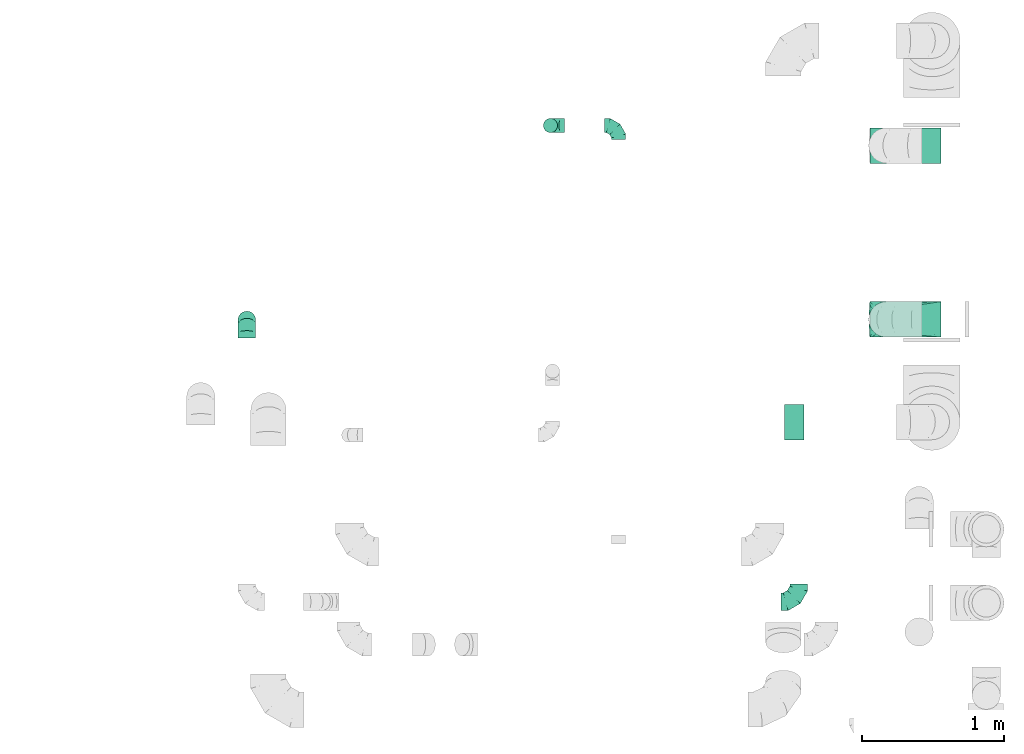
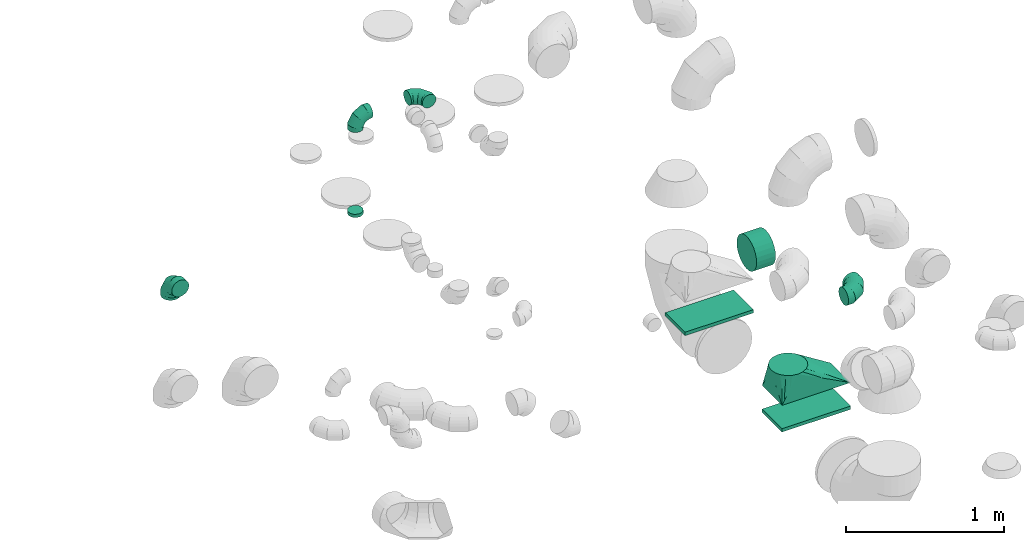
# One storey, part 43 of 59: 9 flow fittings.
"""IFC2X3 building model written with IfcOpenShell, lengths in millimetres."""

import ifcopenshell
import ifcopenshell.guid

model = None  # the IFC model being written
_history = None  # IfcOwnerHistory: only IFC2X3 demands one
_inside = {}  # id of a spatial element -> (the spatial element, [elements in it])
_under = {}  # id of a project, library or spatial element -> (it, [spatial elements below it])
_declared = {}  # id of a project -> (the project, [libraries it declares])
_typed = {}  # id of a type object -> (the type object, [elements of that type])
_made_of = {}  # id of a material, layer set ... -> (it, [elements and type objects made of it])


def new_model(schema):
    """Start an empty IFC model of exactly this schema.

    Asked for "IFC4X3", IfcOpenShell would pick the latest addendum, in which some entities
    have other attributes; the version numbers below select the first issue.
    IFC2X3 requires an IfcOwnerHistory on every rooted entity: one is made here for all.
    """
    global model, _history
    if schema == "IFC4X3":
        model = ifcopenshell.file(schema_version=(4, 3, 0, 0))
    else:
        model = ifcopenshell.file(schema=schema)
    _inside.clear()
    _under.clear()
    _declared.clear()
    _typed.clear()
    _made_of.clear()
    _history = None
    if model.schema == "IFC2X3":
        org = make("IfcOrganization", Name="unknown")
        user = make(
            "IfcPersonAndOrganization",
            ThePerson=make("IfcPerson", FamilyName="unknown"),
            TheOrganization=org,
        )
        app = make(
            "IfcApplication",
            ApplicationDeveloper=org,
            Version="unknown",
            ApplicationFullName="unknown",
            ApplicationIdentifier="unknown",
        )
        _history = make(
            "IfcOwnerHistory",
            OwningUser=user,
            OwningApplication=app,
            ChangeAction="ADDED",
            CreationDate=0,
        )
    return model


def make(cls, **values):
    """One entity of the class cls with the attributes given. An attribute that is None is left unset."""
    return model.create_entity(
        cls, **{name: value for name, value in values.items() if value is not None}
    )


def entity(cls, *values):
    """Any entity or typed value of the class cls, its attributes in the order of the schema. None: left unset."""
    e = model.create_entity(cls)
    for i, value in enumerate(values):
        if value is not None:
            e[i] = value
    return e


def rooted(cls, **values):
    """An entity with a GlobalId (a new one), such as an element, a storey or a relation."""
    return make(cls, GlobalId=ifcopenshell.guid.new(), OwnerHistory=_history, **values)


def si_unit(unit_type, name, prefix=None):
    """IfcSIUnit, for example si_unit("LENGTHUNIT", "METRE", prefix="MILLI")."""
    return make("IfcSIUnit", UnitType=unit_type, Prefix=prefix, Name=name)


def converted_unit(unit_type, name, factor, base, dimensions=None, offset=None):
    """IfcConversionBasedUnit, such as the inch: factor (a typed value) times the base unit."""
    return make(
        "IfcConversionBasedUnit"
        if offset is None
        else "IfcConversionBasedUnitWithOffset",
        ConversionOffset=offset,
        Dimensions=None
        if dimensions is None
        else entity("IfcDimensionalExponents", *dimensions),
        UnitType=unit_type,
        Name=name,
        ConversionFactor=make(
            "IfcMeasureWithUnit", ValueComponent=factor, UnitComponent=base
        ),
    )


def derived_unit(unit_type, elements):
    """IfcDerivedUnit: a product of units, each with its exponent."""
    return make(
        "IfcDerivedUnit",
        Elements=[
            make("IfcDerivedUnitElement", Unit=unit, Exponent=power)
            for unit, power in elements
        ],
        UnitType=unit_type,
    )


def assignment(units):
    """IfcUnitAssignment: the units of a project."""
    return None if units is None else make("IfcUnitAssignment", Units=units)


def point(xyz):
    """IfcCartesianPoint."""
    return None if xyz is None else make("IfcCartesianPoint", Coordinates=xyz)


def direction(xyz):
    """IfcDirection."""
    return None if xyz is None else make("IfcDirection", DirectionRatios=xyz)


def frame(location, z_axis=None, x_axis=None):
    """IfcAxis2Placement3D, a coordinate frame: its origin and axes. An axis left out is left unset."""
    return make(
        "IfcAxis2Placement3D",
        Location=point(location),
        Axis=direction(z_axis),
        RefDirection=direction(x_axis),
    )


def frame_2d(location, x_axis=None):
    """IfcAxis2Placement2D, a coordinate frame in the plane: its origin and x axis."""
    return make(
        "IfcAxis2Placement2D", Location=point(location), RefDirection=direction(x_axis)
    )


def origin():
    """The frame at (0, 0, 0) with its axes left unset."""
    return frame((0.0, 0.0, 0.0))


def origin_2d_with_axis():
    """The frame at (0, 0) in the plane with the x axis (1, 0) written out."""
    return frame_2d((0.0, 0.0), x_axis=(1.0, 0.0))


def place(relative_to, where):
    """IfcLocalPlacement: puts the frame where relative to a parent placement (None: the world)."""
    return make(
        "IfcLocalPlacement", PlacementRelTo=relative_to, RelativePlacement=where
    )


def context(
    kind, dimensions, precision=None, world=None, true_north=None, identifier=None
):
    """IfcGeometricRepresentationContext, for example the 3D "Model" context."""
    return make(
        "IfcGeometricRepresentationContext",
        ContextIdentifier=identifier,
        ContextType=kind,
        CoordinateSpaceDimension=dimensions,
        Precision=precision,
        WorldCoordinateSystem=world,
        TrueNorth=true_north,
    )


def subcontext(parent, identifier, kind, view, scale=None):
    """IfcGeometricRepresentationSubContext, for example "Body" below "Model"."""
    return make(
        "IfcGeometricRepresentationSubContext",
        ContextIdentifier=identifier,
        ContextType=kind,
        ParentContext=parent,
        TargetScale=scale,
        TargetView=view,
    )


def project(units=None, contexts=None):
    """IfcProject with its units and contexts."""
    return rooted(
        "IfcProject",
        Name="project",
        RepresentationContexts=contexts,
        UnitsInContext=assignment(units),
    )


def spatial(cls, under=None, at=None, **own):
    """A site, building, storey or space (cls), placed at a placement, below another one or the project."""
    s = rooted(cls, ObjectPlacement=at, **own)
    if under is not None:
        _under.setdefault(under.id(), (under, []))[1].append(s)
    return s


def profile(cls, at=None, kind="AREA", **sizes):
    """A parametric profile (cls). Its sizes go by their IFC names, for example OverallWidth=200.0."""
    return make(cls, ProfileType=kind, Position=at, **sizes)


def rectangle(**sizes):
    """IfcRectangleProfileDef."""
    return profile("IfcRectangleProfileDef", **sizes)


def circle(**sizes):
    """IfcCircleProfileDef."""
    return profile("IfcCircleProfileDef", **sizes)


def extrude(swept, where, along, depth):
    """IfcExtrudedAreaSolid: the profile swept, set in the frame where, extruded along a direction by depth."""
    return make(
        "IfcExtrudedAreaSolid",
        SweptArea=swept,
        Position=where,
        ExtrudedDirection=direction(along),
        Depth=depth,
    )


def faces_of(points, faces, orient=None, outer=None):
    """IfcFace entities. A face is a list of loops; a loop is a list of indices into points, from 0.

    orient and outer hold one flag for each loop. By default every Orientation is true, the
    first loop of a face is its IfcFaceOuterBound and the others are IfcFaceBound.
    """
    made = []
    for i, loops in enumerate(faces):
        bounds = []
        for j, loop in enumerate(loops):
            is_outer = j == 0 if outer is None else outer[i][j]
            bounds.append(
                make(
                    "IfcFaceOuterBound" if is_outer else "IfcFaceBound",
                    Bound=make("IfcPolyLoop", Polygon=[points[k] for k in loop]),
                    Orientation=True if orient is None else orient[i][j],
                )
            )
        made.append(make("IfcFace", Bounds=bounds))
    return made


def faceted_brep(points, faces, orient=None, outer=None, voids=None):
    """IfcFacetedBrep: a solid bounded by flat faces; with voids (closed shells), ...WithVoids."""
    shared = [point(p) for p in points]
    hull = make("IfcClosedShell", CfsFaces=faces_of(shared, faces, orient, outer))
    if voids is None:
        return make("IfcFacetedBrep", Outer=hull)
    return make(
        "IfcFacetedBrepWithVoids",
        Outer=hull,
        Voids=[
            make(cls, CfsFaces=faces_of(shared, fs, o, b)) for cls, fs, o, b in voids
        ],
    )


def shape(context_of_items, identifier, shape_type, items):
    """IfcShapeRepresentation: the items that make up one representation, for example the "Body"."""
    return make(
        "IfcShapeRepresentation",
        ContextOfItems=context_of_items,
        RepresentationIdentifier=identifier,
        RepresentationType=shape_type,
        Items=items,
    )


def source(mapping_origin, context_of_items, identifier, shape_type, items):
    """IfcRepresentationMap: a shape defined once, which mapped items show again and again."""
    return make(
        "IfcRepresentationMap",
        MappingOrigin=mapping_origin,
        MappedRepresentation=shape(context_of_items, identifier, shape_type, items),
    )


def transform(
    local_origin,
    x_axis=None,
    y_axis=None,
    z_axis=None,
    scale=None,
    scale2=None,
    scale3=None,
    uniform=True,
):
    """IfcCartesianTransformationOperator3D, or its non-uniform kind. x_axis, y_axis, z_axis: its Axis1, 2, 3."""
    if uniform:
        return make(
            "IfcCartesianTransformationOperator3D",
            Axis1=direction(x_axis),
            Axis2=direction(y_axis),
            LocalOrigin=point(local_origin),
            Scale=scale,
            Axis3=direction(z_axis),
        )
    return make(
        "IfcCartesianTransformationOperator3DnonUniform",
        Axis1=direction(x_axis),
        Axis2=direction(y_axis),
        LocalOrigin=point(local_origin),
        Scale=scale,
        Axis3=direction(z_axis),
        Scale2=scale2,
        Scale3=scale3,
    )


def mapped(mapping_source, mapping_target):
    """IfcMappedItem: shows the shape of a source again, moved by a transform."""
    return make(
        "IfcMappedItem", MappingSource=mapping_source, MappingTarget=mapping_target
    )


def material(Name=None, Category=None):
    """IfcMaterial."""
    return make("IfcMaterial", Name=Name, Category=Category)


def made_of(thing, what):
    """Note that an element or type object is made of a material, layer set ...; save() writes the relation."""
    if what is not None:
        _made_of.setdefault(what.id(), (what, []))[1].append(thing)
    return thing


def type_object(cls, material=None, **own):
    """A type object (cls), such as IfcWallType, which elements share."""
    return made_of(rooted(cls, **own), material)


def type_shapes(of_type, sources):
    """Give a type object the sources (RepresentationMaps) that its elements show as mapped items."""
    of_type.RepresentationMaps = sources


def element(
    cls,
    number,
    at=None,
    inside=None,
    cuts=None,
    type_object=None,
    material=None,
    context=None,
    identifier="Body",
    shape_type=None,
    held_by="IfcProductDefinitionShape",
    body=None,
    shapes=None,
    **own,
):
    """One element of the class cls, such as IfcWall. Its Tag is "e" and its number.

    at: its placement. inside: the storey or other place that contains it. cuts: it is an
    opening in that element (IfcRelVoidsElement). A single representation is given by context,
    identifier, shape_type and body (its items); several are given by shapes. held_by: the class
    of the entity that holds the representations. save() writes the other relations.
    """
    e = rooted(cls, Tag="e%d" % number, ObjectPlacement=at, **own)
    if body is not None:
        shapes = [shape(context, identifier, shape_type, body)]
    if shapes is not None:
        e.Representation = make(held_by, Representations=shapes)
    if inside is not None:
        _inside.setdefault(inside.id(), (inside, []))[1].append(e)
    if cuts is not None:
        rooted(
            "IfcRelVoidsElement", RelatingBuildingElement=cuts, RelatedOpeningElement=e
        )
    if type_object is not None:
        _typed.setdefault(type_object.id(), (type_object, []))[1].append(e)
    return made_of(e, material)


def aggregate(whole, parts):
    """IfcRelAggregates: a whole, such as a stair, and the parts it consists of."""
    return rooted("IfcRelAggregates", RelatingObject=whole, RelatedObjects=parts)


def save(model, path):
    """Write the relations noted so far, then the file.

    IfcRelAggregates (storeys below a building ...), IfcRelContainedInSpatialStructure (elements
    in a storey), IfcRelDefinesByType, IfcRelAssociatesMaterial and IfcRelDeclares: one each for
    every whole, place, type object, material and project.
    """
    for whole, parts in _under.values():
        aggregate(whole, parts)
    for where, things in _inside.values():
        rooted(
            "IfcRelContainedInSpatialStructure",
            RelatedElements=things,
            RelatingStructure=where,
        )
    for kind, things in _typed.values():
        rooted("IfcRelDefinesByType", RelatedObjects=things, RelatingType=kind)
    for what, things in _made_of.values():
        rooted("IfcRelAssociatesMaterial", RelatedObjects=things, RelatingMaterial=what)
    for by, libraries in _declared.values():
        rooted("IfcRelDeclares", RelatingContext=by, RelatedDefinitions=libraries)
    model.write(path)


model = new_model("IFC2X3")

# Units and contexts
model_context = context("Model", 3, precision=0.01, world=origin(), true_north=direction((6.12303176911189e-17, 1.0)))
body_context = subcontext(model_context, "Body", "Model", "MODEL_VIEW")
ifc_project = project(units=[si_unit("LENGTHUNIT", "METRE", prefix="MILLI"), si_unit("AREAUNIT", "SQUARE_METRE"), si_unit("VOLUMEUNIT", "CUBIC_METRE"), converted_unit("PLANEANGLEUNIT", "DEGREE", entity("IfcRatioMeasure", 0.0174532925199433), si_unit("PLANEANGLEUNIT", "RADIAN"), dimensions=[0, 0, 0, 0, 0, 0, 0]), si_unit("MASSUNIT", "GRAM", prefix="KILO"), derived_unit("MASSDENSITYUNIT", [(si_unit("MASSUNIT", "GRAM", prefix="KILO"), 1), (si_unit("LENGTHUNIT", "METRE"), -3)]), derived_unit("MOMENTOFINERTIAUNIT", [(si_unit("LENGTHUNIT", "METRE"), 4)]), si_unit("TIMEUNIT", "SECOND"), si_unit("FREQUENCYUNIT", "HERTZ"), si_unit("THERMODYNAMICTEMPERATUREUNIT", "DEGREE_CELSIUS"), derived_unit("THERMALTRANSMITTANCEUNIT", [(si_unit("MASSUNIT", "GRAM", prefix="KILO"), 1), (si_unit("THERMODYNAMICTEMPERATUREUNIT", "KELVIN"), -1), (si_unit("TIMEUNIT", "SECOND"), -3)]), derived_unit("VOLUMETRICFLOWRATEUNIT", [(si_unit("LENGTHUNIT", "METRE"), 3), (si_unit("TIMEUNIT", "SECOND"), -1)]), derived_unit("MASSFLOWRATEUNIT", [(si_unit("MASSUNIT", "GRAM", prefix="KILO"), 1), (si_unit("TIMEUNIT", "SECOND"), -1)]), derived_unit("ROTATIONALFREQUENCYUNIT", [(si_unit("TIMEUNIT", "SECOND"), -1)]), si_unit("ELECTRICCURRENTUNIT", "AMPERE"), si_unit("ELECTRICVOLTAGEUNIT", "VOLT"), si_unit("POWERUNIT", "WATT"), si_unit("FORCEUNIT", "NEWTON", prefix="KILO"), si_unit("ILLUMINANCEUNIT", "LUX"), si_unit("LUMINOUSFLUXUNIT", "LUMEN"), si_unit("LUMINOUSINTENSITYUNIT", "CANDELA"), derived_unit("USERDEFINED", [(si_unit("MASSUNIT", "GRAM", prefix="KILO"), -1), (si_unit("LENGTHUNIT", "METRE"), -2), (si_unit("TIMEUNIT", "SECOND"), 3), (si_unit("LUMINOUSFLUXUNIT", "LUMEN"), 1)]), derived_unit("LINEARVELOCITYUNIT", [(si_unit("LENGTHUNIT", "METRE"), 1), (si_unit("TIMEUNIT", "SECOND"), -1)]), si_unit("PRESSUREUNIT", "PASCAL"), derived_unit("USERDEFINED", [(si_unit("LENGTHUNIT", "METRE"), -2), (si_unit("MASSUNIT", "GRAM", prefix="KILO"), 1), (si_unit("TIMEUNIT", "SECOND"), -2)]), derived_unit("LINEARFORCEUNIT", [(si_unit("MASSUNIT", "GRAM", prefix="KILO"), 1), (si_unit("LENGTHUNIT", "METRE"), 1), (si_unit("TIMEUNIT", "SECOND"), -2), (si_unit("LENGTHUNIT", "METRE"), -1)]), derived_unit("PLANARFORCEUNIT", [(si_unit("MASSUNIT", "GRAM", prefix="KILO"), 1), (si_unit("LENGTHUNIT", "METRE"), 1), (si_unit("TIMEUNIT", "SECOND"), -2), (si_unit("LENGTHUNIT", "METRE"), -2)])], contexts=[model_context])

# Site, building, storey
site_placement = place(None, origin())
site = spatial("IfcSite", under=ifc_project, at=site_placement, CompositionType="ELEMENT")
building_placement = place(site_placement, origin())
building = spatial("IfcBuilding", under=site, at=building_placement, CompositionType="ELEMENT")
storey_placement = place(building_placement, frame((0.0, 0.0, 28200.0)))
storey = spatial("IfcBuildingStorey", under=building, at=storey_placement, CompositionType="ELEMENT", Elevation=28200.0)

# Flow fittings
ifc_material = material()
duct_fitting_type_1 = type_object("IfcDuctFittingType", PredefinedType="NOTDEFINED", material=ifc_material)
shared_shape_1 = source(origin(), body_context, "Body", "SweptSolid", [
    extrude(rectangle(XDim=250.0, YDim=26.0960000001597, at=origin_2d_with_axis()), frame((6.95, 0.0, -250.0), z_axis=(0.0, 0.0, 1.0), x_axis=(0.0, -1.0, 0.0)), (0.0, 0.0, 1.0), 500.0),
])
type_shapes(duct_fitting_type_1, [shared_shape_1])
flow_fitting_1_placement = place(storey_placement, frame((72524.97, 13207.7, 1050.0), z_axis=(1.0, 0.0, 0.0), x_axis=(0.0, 0.0, 1.0)))
element("IfcFlowFitting", 1, at=flow_fitting_1_placement, inside=storey, type_object=duct_fitting_type_1, material=ifc_material, context=body_context, shape_type="MappedRepresentation", body=[
    mapped(shared_shape_1, transform((0.0, 0.0, 0.0), scale=1.0)),
])
duct_fitting_type_2 = type_object("IfcDuctFittingType", PredefinedType="NOTDEFINED", material=ifc_material)
shared_shape_2 = source(origin(), body_context, "Body", "SweptSolid", [
    extrude(circle(Radius=49.9999999999997, at=origin_2d_with_axis()), frame((0.0, 0.0, 0.0), z_axis=(1.0, 0.0, 0.0), x_axis=(0.0, 1.0, 0.0)), (0.0, 0.0, 1.0), 25.0000000000018),
])
type_shapes(duct_fitting_type_2, [shared_shape_2])
flow_fitting_2_placement = place(storey_placement, frame((70026.3, 13348.42, 2640.0), z_axis=(-1.0, 0.0, 0.0), x_axis=(0.0, 0.0, -1.0)))
element("IfcFlowFitting", 2, at=flow_fitting_2_placement, inside=storey, type_object=duct_fitting_type_2, material=ifc_material, context=body_context, shape_type="MappedRepresentation", body=[
    mapped(shared_shape_2, transform((0.0, 0.0, 0.0), scale=1.0)),
])
duct_fitting_type_3 = type_object("IfcDuctFittingType", PredefinedType="NOTDEFINED", material=ifc_material)
shared_shape_3 = source(origin(), body_context, "Body", "SweptSolid", [
    extrude(rectangle(XDim=26.0960000000177, YDim=250.0, at=origin_2d_with_axis()), frame((6.95, 0.0, -250.0)), (0.0, 0.0, 1.0), 500.0),
])
type_shapes(duct_fitting_type_3, [shared_shape_3])
flow_fitting_3_placement = place(storey_placement, frame((72524.97, 11982.7, 1050.0), z_axis=(-1.0, 0.0, 0.0), x_axis=(0.0, 0.0, 1.0)))
element("IfcFlowFitting", 3, at=flow_fitting_3_placement, inside=storey, type_object=duct_fitting_type_3, material=ifc_material, context=body_context, shape_type="MappedRepresentation", body=[
    mapped(shared_shape_3, transform((0.0, 0.0, 0.0), scale=1.0)),
])
duct_fitting_type_4 = type_object("IfcDuctFittingType", PredefinedType="NOTDEFINED", material=ifc_material)
shared_shape_4 = source(origin(), body_context, "Body", "Brep", [
    faceted_brep([(-100.0, 0.0, -50.0), (-100.0, -12.94, -48.3), (-100.0, -25.0, -43.3), (-100.0, -35.36, -35.36), (-100.0, -43.3, -25.0), (-100.0, -48.3, -12.94), (-100.0, -50.0, 0.0), (-100.0, -48.3, 12.94), (-100.0, -43.3, 25.0), (-100.0, -35.36, 35.36), (-100.0, -25.0, 43.3), (-100.0, -12.94, 48.3), (-100.0, 0.0, 50.0), (-100.0, 12.94, 48.3), (-100.0, 25.0, 43.3), (-100.0, 35.36, 35.36), (-100.0, 43.3, 25.0), (-100.0, 48.3, 12.94), (-100.0, 50.0, 0.0), (-100.0, 48.3, -12.94), (-100.0, 43.3, -25.0), (-100.0, 35.36, -35.36), (-100.0, 25.0, -43.3), (-100.0, 12.94, -48.3), (-76.67, 12.94, 48.3), (-79.9, 25.0, 43.3), (-73.21, 0.0, 50.0), (-82.68, 35.36, 35.36), (-86.15, 48.3, 12.94), (-86.6, 50.0, 0.0), (-84.81, 43.3, 25.0), (-84.81, 43.3, -25.0), (-82.68, 35.36, -35.36), (-86.15, 48.3, -12.94), (-76.67, 12.94, -48.3), (-73.21, 0.0, -50.0), (-79.9, 25.0, -43.3), (-69.74, -12.94, -48.3), (-66.51, -25.0, -43.3), (-63.73, -35.36, -35.36), (-61.6, -43.3, -25.0), (-60.26, -48.3, -12.94), (-59.81, -50.0, 0.0), (-60.26, -48.3, 12.94), (-61.6, -43.3, 25.0), (-63.73, -35.36, 35.36), (-66.51, -25.0, 43.3), (-69.74, -12.94, 48.3), (-36.27, 36.27, 48.3), (-45.1, 45.1, 43.3), (-26.79, 26.79, 50.0), (-52.68, 52.68, 35.36), (-58.49, 58.49, 25.0), (-62.15, 62.15, 12.94), (-63.4, 63.4, 0.0), (-62.15, 62.15, -12.94), (-58.49, 58.49, -25.0), (-52.68, 52.68, -35.36), (-36.27, 36.27, -48.3), (-26.79, 26.79, -50.0), (-45.1, 45.1, -43.3), (-17.32, 17.32, -48.3), (-8.49, 8.49, -43.3), (-0.91, 0.91, -35.36), (4.9, -4.9, -25.0), (8.56, -8.56, -12.94), (9.81, -9.81, 0.0), (8.56, -8.56, 12.94), (4.9, -4.9, 25.0), (-0.91, 0.91, 35.36), (-8.49, 8.49, 43.3), (-17.32, 17.32, 48.3), (-12.94, 76.67, 48.3), (-25.0, 79.9, 43.3), (0.0, 73.21, 50.0), (-35.36, 82.68, 35.36), (-43.3, 84.81, 25.0), (-48.3, 86.15, 12.94), (-50.0, 86.6, 0.0), (-48.3, 86.15, -12.94), (-43.3, 84.81, -25.0), (-35.36, 82.68, -35.36), (-12.94, 76.67, -48.3), (0.0, 73.21, -50.0), (-25.0, 79.9, -43.3), (12.94, 69.74, -48.3), (25.0, 66.51, -43.3), (35.36, 63.73, -35.36), (43.3, 61.6, -25.0), (48.3, 60.26, -12.94), (50.0, 59.81, 0.0), (48.3, 60.26, 12.94), (43.3, 61.6, 25.0), (35.36, 63.73, 35.36), (25.0, 66.51, 43.3), (12.94, 69.74, 48.3), (-12.94, 100.0, -48.3), (-25.0, 100.0, -43.3), (-35.36, 100.0, -35.36), (-43.3, 100.0, -25.0), (-48.3, 100.0, -12.94), (-50.0, 100.0, 0.0), (-48.3, 100.0, 12.94), (-43.3, 100.0, 25.0), (-35.36, 100.0, 35.36), (-25.0, 100.0, 43.3), (-12.94, 100.0, 48.3), (0.0, 100.0, 50.0), (12.94, 100.0, 48.3), (25.0, 100.0, 43.3), (35.36, 100.0, 35.36), (43.3, 100.0, 25.0), (48.3, 100.0, 12.94), (50.0, 100.0, 0.0), (48.3, 100.0, -12.94), (43.3, 100.0, -25.0), (35.36, 100.0, -35.36), (25.0, 100.0, -43.3), (12.94, 100.0, -48.3), (0.0, 100.0, -50.0)], [[[0, 1, 2, 3, 4, 5, 6, 7, 8, 9, 10, 11, 12, 13, 14, 15, 16, 17, 18, 19, 20, 21, 22, 23]], [[24, 25, 14, 13]], [[26, 24, 13, 12]], [[14, 25, 27, 15]], [[28, 29, 18, 17]], [[30, 28, 17, 16]], [[15, 27, 30, 16]], [[20, 31, 32, 21]], [[33, 31, 20, 19]], [[18, 29, 33, 19]], [[34, 35, 0, 23]], [[36, 34, 23, 22]], [[32, 36, 22, 21]], [[2, 1, 37, 38]], [[3, 2, 38, 39]], [[0, 35, 37, 1]], [[5, 4, 40, 41]], [[6, 5, 41, 42]], [[3, 39, 40, 4]], [[6, 42, 43, 7]], [[7, 43, 44, 8]], [[8, 44, 45, 9]], [[10, 46, 47, 11]], [[11, 47, 26, 12]], [[10, 9, 45, 46]], [[48, 49, 25, 24]], [[50, 48, 24, 26]], [[27, 25, 49, 51]], [[52, 53, 28, 30]], [[51, 52, 30, 27]], [[29, 28, 53, 54]], [[55, 56, 31, 33]], [[54, 55, 33, 29]], [[57, 32, 31, 56]], [[58, 59, 35, 34]], [[60, 58, 34, 36]], [[57, 60, 36, 32]], [[37, 35, 59, 61]], [[38, 37, 61, 62]], [[39, 38, 62, 63]], [[41, 40, 64, 65]], [[42, 41, 65, 66]], [[63, 64, 40, 39]], [[43, 42, 66, 67]], [[44, 43, 67, 68]], [[68, 69, 45, 44]], [[46, 45, 69, 70]], [[47, 46, 70, 71]], [[26, 47, 71, 50]], [[72, 73, 49, 48]], [[74, 72, 48, 50]], [[51, 49, 73, 75]], [[76, 77, 53, 52]], [[75, 76, 52, 51]], [[54, 53, 77, 78]], [[79, 80, 56, 55]], [[78, 79, 55, 54]], [[81, 57, 56, 80]], [[82, 83, 59, 58]], [[84, 82, 58, 60]], [[81, 84, 60, 57]], [[61, 59, 83, 85]], [[62, 61, 85, 86]], [[63, 62, 86, 87]], [[65, 64, 88, 89]], [[66, 65, 89, 90]], [[87, 88, 64, 63]], [[67, 66, 90, 91]], [[68, 67, 91, 92]], [[92, 93, 69, 68]], [[70, 69, 93, 94]], [[71, 70, 94, 95]], [[50, 71, 95, 74]], [[96, 97, 98, 99, 100, 101, 102, 103, 104, 105, 106, 107, 108, 109, 110, 111, 112, 113, 114, 115, 116, 117, 118, 119]], [[72, 74, 107, 106]], [[73, 72, 106, 105]], [[75, 73, 105, 104]], [[77, 76, 103, 102]], [[78, 77, 102, 101]], [[75, 104, 103, 76]], [[78, 101, 100, 79]], [[79, 100, 99, 80]], [[80, 99, 98, 81]], [[96, 119, 83, 82]], [[97, 96, 82, 84]], [[84, 81, 98, 97]], [[83, 119, 118, 85]], [[85, 118, 117, 86]], [[86, 117, 116, 87]], [[88, 115, 114, 89]], [[89, 114, 113, 90]], [[87, 116, 115, 88]], [[91, 90, 113, 112]], [[92, 91, 112, 111]], [[93, 92, 111, 110]], [[95, 94, 109, 108]], [[74, 95, 108, 107]], [[110, 109, 94, 93]]]),
])
type_shapes(duct_fitting_type_4, [shared_shape_4])
for number, where, z_axis, x_axis in (
    (4, (70506.3, 13348.42, 3370.0), (0.0, 0.0, 1.0), (0.0, 1.0, 0.0)),
    (5, (70026.3, 13348.42, 3370.0), (0.0, -1.0, 0.0), (-1.0, 0.0, 0.0)),
):
    element("IfcFlowFitting", number, at=place(storey_placement, frame(where, z_axis=z_axis, x_axis=x_axis)), inside=storey, type_object=duct_fitting_type_4, material=ifc_material, context=body_context, shape_type="MappedRepresentation", body=[
        mapped(shared_shape_4, transform((0.0, 0.0, 0.0), scale=1.0)),
    ])
duct_fitting_type_5 = type_object("IfcDuctFittingType", PredefinedType="NOTDEFINED", material=ifc_material)
shared_shape_5 = source(origin(), body_context, "Body", "Brep", [
    faceted_brep([(-125.0, 0.0, -62.5), (-125.0, -16.18, -60.37), (-125.0, -31.25, -54.13), (-125.0, -44.19, -44.19), (-125.0, -54.13, -31.25), (-125.0, -60.37, -16.18), (-125.0, -62.5, 0.0), (-125.0, -60.37, 16.18), (-125.0, -54.13, 31.25), (-125.0, -44.19, 44.19), (-125.0, -31.25, 54.13), (-125.0, -16.18, 60.37), (-125.0, 0.0, 62.5), (-125.0, 16.18, 60.37), (-125.0, 31.25, 54.13), (-125.0, 44.19, 44.19), (-125.0, 54.13, 31.25), (-125.0, 60.37, 16.18), (-125.0, 62.5, 0.0), (-125.0, 60.37, -16.18), (-125.0, 54.13, -31.25), (-125.0, 44.19, -44.19), (-125.0, 31.25, -54.13), (-125.0, 16.18, -60.37), (-95.84, 16.18, 60.37), (-99.88, 31.25, 54.13), (-91.51, 0.0, 62.5), (-103.35, 44.19, 44.19), (-107.68, 60.37, 16.18), (-108.25, 62.5, 0.0), (-106.01, 54.13, 31.25), (-106.01, 54.13, -31.25), (-103.35, 44.19, -44.19), (-107.68, 60.37, -16.18), (-95.84, 16.18, -60.37), (-91.51, 0.0, -62.5), (-99.88, 31.25, -54.13), (-87.17, -16.18, -60.37), (-83.13, -31.25, -54.13), (-79.66, -44.19, -44.19), (-77.0, -54.13, -31.25), (-75.33, -60.37, -16.18), (-74.76, -62.5, 0.0), (-75.33, -60.37, 16.18), (-77.0, -54.13, 31.25), (-79.66, -44.19, 44.19), (-83.13, -31.25, 54.13), (-87.17, -16.18, 60.37), (-45.34, 45.34, 60.37), (-56.37, 56.37, 54.13), (-33.49, 33.49, 62.5), (-65.85, 65.85, 44.19), (-73.12, 73.12, 31.25), (-77.69, 77.69, 16.18), (-79.25, 79.25, 0.0), (-77.69, 77.69, -16.18), (-73.12, 73.12, -31.25), (-65.85, 65.85, -44.19), (-45.34, 45.34, -60.37), (-33.49, 33.49, -62.5), (-56.37, 56.37, -54.13), (-21.65, 21.65, -60.37), (-10.62, 10.62, -54.13), (-1.14, 1.14, -44.19), (6.13, -6.13, -31.25), (10.7, -10.7, -16.18), (12.26, -12.26, 0.0), (10.7, -10.7, 16.18), (6.13, -6.13, 31.25), (-1.14, 1.14, 44.19), (-10.62, 10.62, 54.13), (-21.65, 21.65, 60.37), (-16.18, 95.84, 60.37), (-31.25, 99.88, 54.13), (0.0, 91.51, 62.5), (-44.19, 103.35, 44.19), (-54.13, 106.01, 31.25), (-60.37, 107.68, 16.18), (-62.5, 108.25, 0.0), (-60.37, 107.68, -16.18), (-54.13, 106.01, -31.25), (-44.19, 103.35, -44.19), (-16.18, 95.84, -60.37), (0.0, 91.51, -62.5), (-31.25, 99.88, -54.13), (16.18, 87.17, -60.37), (31.25, 83.13, -54.13), (44.19, 79.66, -44.19), (54.13, 77.0, -31.25), (60.37, 75.33, -16.18), (62.5, 74.76, 0.0), (60.37, 75.33, 16.18), (54.13, 77.0, 31.25), (44.19, 79.66, 44.19), (31.25, 83.13, 54.13), (16.18, 87.17, 60.37), (-16.18, 125.0, -60.37), (-31.25, 125.0, -54.13), (-44.19, 125.0, -44.19), (-54.13, 125.0, -31.25), (-60.37, 125.0, -16.18), (-62.5, 125.0, 0.0), (-60.37, 125.0, 16.18), (-54.13, 125.0, 31.25), (-44.19, 125.0, 44.19), (-31.25, 125.0, 54.13), (-16.18, 125.0, 60.37), (0.0, 125.0, 62.5), (16.18, 125.0, 60.37), (31.25, 125.0, 54.13), (44.19, 125.0, 44.19), (54.13, 125.0, 31.25), (60.37, 125.0, 16.18), (62.5, 125.0, 0.0), (60.37, 125.0, -16.18), (54.13, 125.0, -31.25), (44.19, 125.0, -44.19), (31.25, 125.0, -54.13), (16.18, 125.0, -60.37), (0.0, 125.0, -62.5)], [[[0, 1, 2, 3, 4, 5, 6, 7, 8, 9, 10, 11, 12, 13, 14, 15, 16, 17, 18, 19, 20, 21, 22, 23]], [[24, 25, 14, 13]], [[26, 24, 13, 12]], [[14, 25, 27, 15]], [[28, 29, 18, 17]], [[30, 28, 17, 16]], [[15, 27, 30, 16]], [[20, 31, 32, 21]], [[33, 31, 20, 19]], [[18, 29, 33, 19]], [[34, 35, 0, 23]], [[36, 34, 23, 22]], [[21, 32, 36, 22]], [[1, 0, 35, 37]], [[2, 1, 37, 38]], [[38, 39, 3, 2]], [[5, 4, 40, 41]], [[6, 5, 41, 42]], [[39, 40, 4, 3]], [[6, 42, 43, 7]], [[7, 43, 44, 8]], [[45, 9, 8, 44]], [[9, 45, 46, 10]], [[10, 46, 47, 11]], [[26, 12, 11, 47]], [[48, 49, 25, 24]], [[50, 48, 24, 26]], [[27, 25, 49, 51]], [[52, 53, 28, 30]], [[51, 52, 30, 27]], [[29, 28, 53, 54]], [[55, 56, 31, 33]], [[54, 55, 33, 29]], [[57, 32, 31, 56]], [[58, 59, 35, 34]], [[60, 58, 34, 36]], [[57, 60, 36, 32]], [[37, 35, 59, 61]], [[38, 37, 61, 62]], [[39, 38, 62, 63]], [[41, 40, 64, 65]], [[42, 41, 65, 66]], [[63, 64, 40, 39]], [[43, 42, 66, 67]], [[44, 43, 67, 68]], [[68, 69, 45, 44]], [[46, 45, 69, 70]], [[47, 46, 70, 71]], [[26, 47, 71, 50]], [[72, 73, 49, 48]], [[74, 72, 48, 50]], [[51, 49, 73, 75]], [[76, 77, 53, 52]], [[75, 76, 52, 51]], [[54, 53, 77, 78]], [[79, 80, 56, 55]], [[78, 79, 55, 54]], [[81, 57, 56, 80]], [[82, 83, 59, 58]], [[84, 82, 58, 60]], [[81, 84, 60, 57]], [[61, 59, 83, 85]], [[62, 61, 85, 86]], [[63, 62, 86, 87]], [[65, 64, 88, 89]], [[66, 65, 89, 90]], [[87, 88, 64, 63]], [[67, 66, 90, 91]], [[68, 67, 91, 92]], [[92, 93, 69, 68]], [[70, 69, 93, 94]], [[71, 70, 94, 95]], [[50, 71, 95, 74]], [[96, 97, 98, 99, 100, 101, 102, 103, 104, 105, 106, 107, 108, 109, 110, 111, 112, 113, 114, 115, 116, 117, 118, 119]], [[72, 74, 107, 106]], [[73, 72, 106, 105]], [[75, 73, 105, 104]], [[77, 76, 103, 102]], [[78, 77, 102, 101]], [[75, 104, 103, 76]], [[78, 101, 100, 79]], [[79, 100, 99, 80]], [[80, 99, 98, 81]], [[96, 119, 83, 82]], [[97, 96, 82, 84]], [[84, 81, 98, 97]], [[83, 119, 118, 85]], [[85, 118, 117, 86]], [[116, 87, 86, 117]], [[88, 115, 114, 89]], [[89, 114, 113, 90]], [[115, 88, 87, 116]], [[91, 90, 113, 112]], [[92, 91, 112, 111]], [[111, 110, 93, 92]], [[95, 94, 109, 108]], [[74, 95, 108, 107]], [[110, 109, 94, 93]]]),
])
type_shapes(duct_fitting_type_5, [shared_shape_5])
flow_fitting_4_placement = place(storey_placement, frame((71773.8, 9995.25, 3440.0)))
element("IfcFlowFitting", 6, at=flow_fitting_4_placement, inside=storey, type_object=duct_fitting_type_5, material=ifc_material, context=body_context, shape_type="MappedRepresentation", body=[
    mapped(shared_shape_5, transform((0.0, 0.0, 0.0), scale=1.0)),
])
flow_fitting_5_placement = place(storey_placement, frame((67888.0, 11978.54, 3690.0), z_axis=(-1.0, 0.0, 0.0), x_axis=(0.0, 1.0, 0.0)))
element("IfcFlowFitting", 7, at=flow_fitting_5_placement, inside=storey, type_object=duct_fitting_type_5, material=ifc_material, context=body_context, shape_type="MappedRepresentation", body=[
    mapped(shared_shape_5, transform((0.0, 0.0, 0.0), scale=1.0)),
])
duct_fitting_type_6 = type_object("IfcDuctFittingType", PredefinedType="NOTDEFINED", material=ifc_material)
shared_shape_6 = source(origin(), body_context, "Body", "Brep", [
    faceted_brep([(20.0, 32.35, -120.74), (20.0, 62.5, -108.25), (20.0, 88.39, -88.39), (20.0, 108.25, -62.5), (20.0, 120.74, -32.35), (20.0, 125.0, 0.0), (20.0, 120.74, 32.35), (20.0, 108.25, 62.5), (20.0, 88.39, 88.39), (20.0, 62.5, 108.25), (20.0, 32.35, 120.74), (20.0, 0.0, 125.0), (20.0, -32.35, 120.74), (20.0, -62.5, 108.25), (20.0, -88.39, 88.39), (20.0, -108.25, 62.5), (20.0, -120.74, 32.35), (20.0, -125.0, 0.0), (20.0, -120.74, -32.35), (20.0, -108.25, -62.5), (20.0, -88.39, -88.39), (20.0, -62.5, -108.25), (20.0, -32.35, -120.74), (20.0, 0.0, -125.0), (0.0, 0.0, 125.0), (0.0, 32.35, 120.74), (-118.9, 32.35, 120.74), (-118.9, 0.0, 125.0), (0.0, 62.5, 108.25), (-118.9, 62.5, 108.25), (0.0, 88.39, 88.39), (-118.9, 88.39, 88.39), (0.0, 108.25, 62.5), (0.0, 120.74, 32.35), (-118.9, 120.74, 32.35), (-118.9, 108.25, 62.5), (0.0, 125.0, 0.0), (-118.9, 125.0, 0.0), (0.0, 120.74, -32.35), (-118.9, 120.74, -32.35), (0.0, 108.25, -62.5), (-118.9, 108.25, -62.5), (0.0, 88.39, -88.39), (-118.9, 88.39, -88.39), (0.0, 62.5, -108.25), (0.0, 32.35, -120.74), (-118.9, 32.35, -120.74), (-118.9, 62.5, -108.25), (0.0, 0.0, -125.0), (-118.9, 0.0, -125.0), (0.0, -32.35, -120.74), (-118.9, -32.35, -120.74), (0.0, -62.5, -108.25), (-118.9, -62.5, -108.25), (0.0, -88.39, -88.39), (-118.9, -88.39, -88.39), (0.0, -108.25, -62.5), (0.0, -120.74, -32.35), (-118.9, -120.74, -32.35), (-118.9, -108.25, -62.5), (0.0, -125.0, 0.0), (-118.9, -125.0, 0.0), (0.0, -120.74, 32.35), (-118.9, -120.74, 32.35), (0.0, -108.25, 62.5), (-118.9, -108.25, 62.5), (0.0, -88.39, 88.39), (-118.9, -88.39, 88.39), (0.0, -62.5, 108.25), (0.0, -32.35, 120.74), (-118.9, -32.35, 120.74), (-118.9, -62.5, 108.25)], [[[0, 1, 2, 3, 4, 5, 6, 7, 8, 9, 10, 11, 12, 13, 14, 15, 16, 17, 18, 19, 20, 21, 22, 23]], [[24, 11, 10, 25, 26, 27]], [[25, 10, 9, 28, 29, 26]], [[28, 9, 8, 30, 31, 29]], [[32, 7, 6, 33, 34, 35]], [[33, 6, 5, 36, 37, 34]], [[30, 8, 7, 32, 35, 31]], [[36, 5, 4, 38, 39, 37]], [[38, 4, 3, 40, 41, 39]], [[40, 3, 2, 42, 43, 41]], [[44, 1, 0, 45, 46, 47]], [[45, 0, 23, 48, 49, 46]], [[42, 2, 1, 44, 47, 43]], [[48, 23, 22, 50, 51, 49]], [[50, 22, 21, 52, 53, 51]], [[52, 21, 20, 54, 55, 53]], [[56, 19, 18, 57, 58, 59]], [[57, 18, 17, 60, 61, 58]], [[54, 20, 19, 56, 59, 55]], [[60, 17, 16, 62, 63, 61]], [[62, 16, 15, 64, 65, 63]], [[64, 15, 14, 66, 67, 65]], [[68, 13, 12, 69, 70, 71]], [[69, 12, 11, 24, 27, 70]], [[66, 14, 13, 68, 71, 67]], [[49, 51, 53, 55, 59, 58, 61, 63, 65, 67, 71, 70, 27, 26, 29, 31, 35, 34, 37, 39, 41, 43, 47, 46]]]),
])
type_shapes(duct_fitting_type_6, [shared_shape_6])
flow_fitting_6_placement = place(storey_placement, frame((71791.81, 11260.58, 3000.0), z_axis=(0.0, 0.0, -1.0), x_axis=(1.0, 0.0, 0.0)))
element("IfcFlowFitting", 8, at=flow_fitting_6_placement, inside=storey, type_object=duct_fitting_type_6, material=ifc_material, context=body_context, shape_type="MappedRepresentation", body=[
    mapped(shared_shape_6, transform((0.0, 0.0, 0.0), scale=1.0)),
])
duct_fitting_type_7 = type_object("IfcDuctFittingType", PredefinedType="NOTDEFINED", material=ifc_material)
shared_shape_7 = source(origin(), body_context, "Body", "Brep", [
    faceted_brep([(200.0, -73.47, -234.29), (200.0, -56.05, -243.17), (200.0, -38.63, -252.04), (200.0, -23.84, -254.38), (200.0, -11.92, -256.27), (200.0, -5.96, -257.22), (200.0, 0.0, -258.16), (200.0, 5.96, -257.22), (200.0, 11.92, -256.27), (200.0, 23.84, -254.38), (200.0, 38.63, -252.04), (200.0, 56.05, -243.17), (200.0, 73.47, -234.29), (200.0, 87.3, -220.46), (200.0, 101.13, -206.63), (200.0, 110.0, -189.21), (200.0, 118.88, -171.79), (200.0, 121.22, -157.0), (200.0, 123.11, -145.08), (200.0, 124.06, -139.12), (200.0, 125.0, -133.16), (200.0, 124.06, -127.2), (200.0, 123.11, -121.24), (200.0, 121.22, -109.32), (200.0, 118.88, -94.53), (200.0, 110.0, -77.11), (200.0, 101.13, -59.69), (200.0, 87.3, -45.86), (200.0, 73.47, -32.03), (200.0, 56.05, -23.16), (200.0, 38.63, -14.28), (200.0, 23.84, -11.94), (200.0, 11.92, -10.05), (200.0, 5.96, -9.1), (200.0, 0.0, -8.16), (200.0, -5.96, -9.1), (200.0, -11.92, -10.05), (200.0, -23.84, -11.94), (200.0, -38.63, -14.28), (200.0, -56.05, -23.16), (200.0, -73.47, -32.03), (200.0, -87.3, -45.86), (200.0, -101.13, -59.69), (200.0, -110.0, -77.11), (200.0, -118.88, -94.53), (200.0, -121.22, -109.32), (200.0, -123.11, -121.24), (200.0, -124.06, -127.2), (200.0, -125.0, -133.16), (200.0, -124.06, -139.12), (200.0, -123.11, -145.08), (200.0, -121.22, -157.0), (200.0, -118.88, -171.79), (200.0, -110.0, -189.21), (200.0, -101.13, -206.63), (200.0, -87.3, -220.46), (0.0, -125.0, 250.0), (0.0, 125.0, 250.0), (0.0, 125.0, -250.0), (0.0, -125.0, -250.0), (104.11, -59.93, 115.61), (100.0, -103.94, 105.21), (26.03, -108.73, 216.4), (78.09, -76.2, 149.21), (52.06, -92.46, 182.8), (188.01, -7.49, 7.31), (176.03, -14.98, 22.78), (152.06, -29.96, 53.72), (128.09, -44.95, 84.67), (52.06, -125.0, 150.27), (78.09, -125.0, 100.4), (104.11, -125.0, 50.54), (128.09, -125.0, 4.61), (152.06, -125.0, -41.31), (176.03, -125.0, -87.24), (188.01, -125.0, -110.2), (26.03, -125.0, 200.13), (26.03, -125.0, -234.79), (52.06, -125.0, -219.59), (78.09, -125.0, -204.38), (104.11, -125.0, -189.18), (128.09, -125.0, -175.17), (152.06, -125.0, -161.17), (176.03, -125.0, -147.16), (188.01, -125.0, -140.16), (100.0, -109.29, -233.02), (52.06, -92.46, -252.12), (78.09, -76.2, -253.19), (104.11, -59.93, -254.25), (128.09, -44.95, -255.23), (152.06, -29.96, -256.2), (176.03, -14.98, -257.18), (188.01, -7.49, -257.67), (26.03, -108.73, -251.06), (26.03, 108.73, -251.06), (52.06, 92.46, -252.12), (78.09, 76.2, -253.19), (104.11, 59.93, -254.25), (128.09, 44.95, -255.23), (152.06, 29.96, -256.2), (176.03, 14.98, -257.18), (188.01, 7.49, -257.67), (100.0, 103.94, -238.37), (52.06, 125.0, -219.59), (78.09, 125.0, -204.38), (104.11, 125.0, -189.18), (128.09, 125.0, -175.17), (152.06, 125.0, -161.17), (176.03, 125.0, -147.16), (188.01, 125.0, -140.16), (26.03, 125.0, -234.79), (26.03, 125.0, 200.13), (52.06, 125.0, 150.27), (78.09, 125.0, 100.4), (104.11, 125.0, 50.54), (128.09, 125.0, 4.61), (152.06, 125.0, -41.31), (176.03, 125.0, -87.24), (188.01, 125.0, -110.2), (100.0, 109.29, 99.86), (52.06, 92.46, 182.8), (78.09, 76.2, 149.21), (104.11, 59.93, 115.61), (128.09, 44.95, 84.67), (152.06, 29.96, 53.72), (176.03, 14.98, 22.78), (188.01, 7.49, 7.31), (26.03, 108.73, 216.4)], [[[0, 1, 2, 3, 4, 5, 6, 7, 8, 9, 10, 11, 12, 13, 14, 15, 16, 17, 18, 19, 20, 21, 22, 23, 24, 25, 26, 27, 28, 29, 30, 31, 32, 33, 34, 35, 36, 37, 38, 39, 40, 41, 42, 43, 44, 45, 46, 47, 48, 49, 50, 51, 52, 53, 54, 55]], [[56, 57, 58, 59]], [[60, 39, 38]], [[56, 61, 62]], [[39, 60, 63, 64]], [[65, 66, 67, 68, 60, 38, 37, 36, 35, 34]], [[62, 61, 40]], [[43, 69, 70, 71]], [[64, 40, 39]], [[44, 71, 72, 73, 74, 75, 48, 47, 46, 45]], [[42, 76, 69]], [[71, 44, 43]], [[61, 76, 41]], [[40, 64, 62]], [[76, 42, 41]], [[40, 61, 41]], [[61, 56, 76]], [[69, 43, 42]], [[75, 74, 73, 72, 71, 70, 69, 76, 56, 59, 77, 78, 79, 80, 81, 82, 83, 84, 48]], [[80, 53, 52]], [[59, 85, 77]], [[53, 80, 79, 78]], [[84, 83, 82, 81, 80, 52, 51, 50, 49, 48]], [[77, 85, 54]], [[1, 86, 87, 88]], [[78, 54, 53]], [[2, 88, 89, 90, 91, 92, 6, 5, 4, 3]], [[0, 93, 86]], [[88, 2, 1]], [[85, 93, 55]], [[54, 78, 77]], [[93, 0, 55]], [[54, 85, 55]], [[85, 59, 93]], [[86, 1, 0]], [[92, 91, 90, 89, 88, 87, 86, 93, 59, 58, 94, 95, 96, 97, 98, 99, 100, 101, 6]], [[97, 11, 10]], [[58, 102, 94]], [[11, 97, 96, 95]], [[101, 100, 99, 98, 97, 10, 9, 8, 7, 6]], [[94, 102, 12]], [[15, 103, 104, 105]], [[95, 12, 11]], [[16, 105, 106, 107, 108, 109, 20, 19, 18, 17]], [[14, 110, 103]], [[105, 16, 15]], [[102, 110, 13]], [[12, 95, 94]], [[110, 14, 13]], [[12, 102, 13]], [[102, 58, 110]], [[103, 15, 14]], [[58, 57, 111, 112, 113, 114, 115, 116, 117, 118, 20, 109, 108, 107, 106, 105, 104, 103, 110]], [[114, 25, 24]], [[57, 119, 111]], [[25, 114, 113, 112]], [[118, 117, 116, 115, 114, 24, 23, 22, 21, 20]], [[111, 119, 26]], [[29, 120, 121, 122]], [[112, 26, 25]], [[30, 122, 123, 124, 125, 126, 34, 33, 32, 31]], [[28, 127, 120]], [[122, 30, 29]], [[119, 127, 27]], [[26, 112, 111]], [[127, 28, 27]], [[26, 119, 27]], [[119, 57, 127]], [[120, 29, 28]], [[57, 56, 62, 64, 63, 60, 68, 67, 66, 65, 34, 126, 125, 124, 123, 122, 121, 120, 127]]]),
])
type_shapes(duct_fitting_type_7, [shared_shape_7])
flow_fitting_7_placement = place(storey_placement, frame((72524.97, 11982.7, 1250.0), z_axis=(1.0, 0.0, 0.0), x_axis=(0.0, 0.0, 1.0)))
element("IfcFlowFitting", 9, at=flow_fitting_7_placement, inside=storey, type_object=duct_fitting_type_7, material=ifc_material, context=body_context, shape_type="MappedRepresentation", body=[
    mapped(shared_shape_7, transform((0.0, 0.0, 0.0), scale=1.0)),
])

save(model, "model.ifc")
